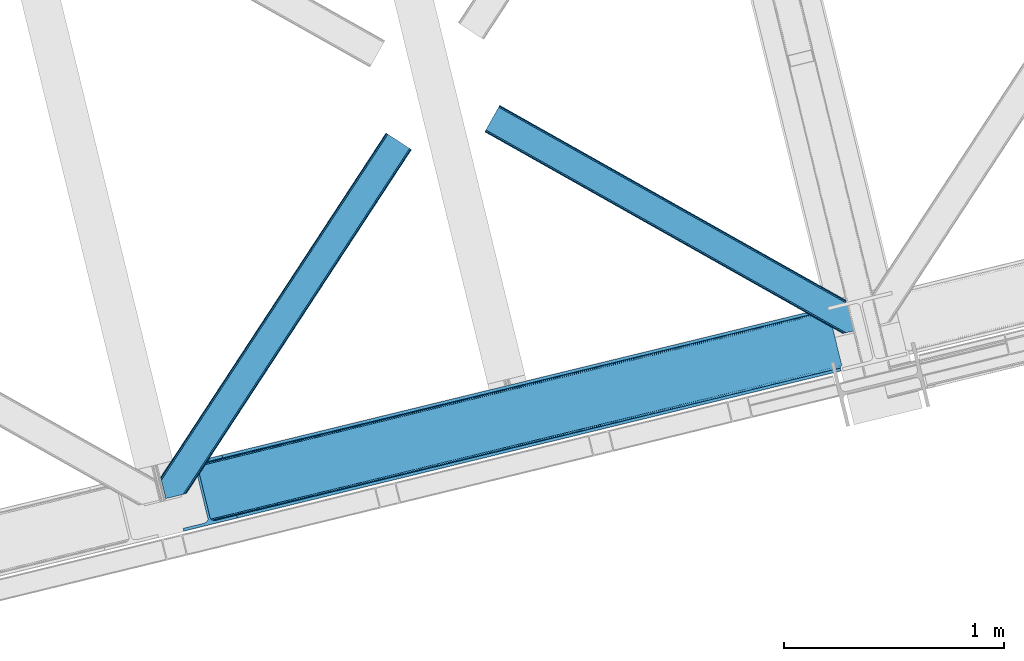
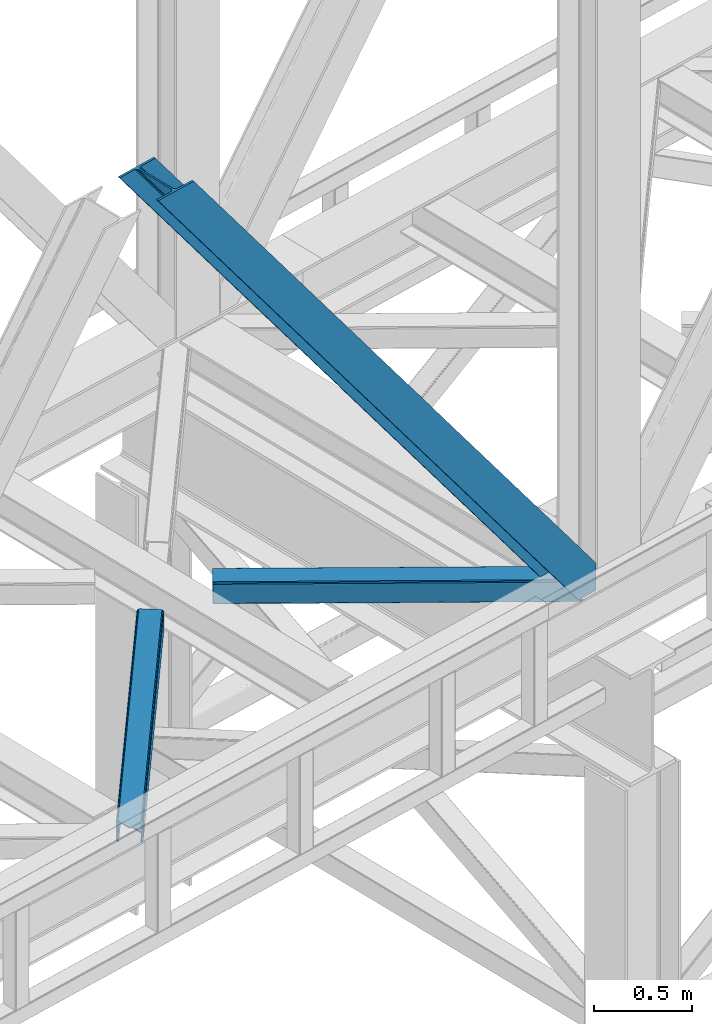
# One storey, part 41 of 93: 3 members.
"""IFC4 building model written with IfcOpenShell, lengths in millimetres."""

from ifc_helpers import new_model, entity, si_unit, converted_unit, derived_unit, direction, frame, origin, place, context, subcontext, project, spatial, triangles, type_object, element, save


model = new_model("IFC4")

# Units and contexts
model_context = context("Model", 3, precision=0.01, world=origin(), true_north=direction((6.12303176911189e-17, 1.0)))
plan_context = context("Plan", 3, precision=0.01, world=origin(), true_north=direction((6.12303176911189e-17, 1.0)))
body_context = subcontext(model_context, "Body", "Model", "MODEL_VIEW")
ifc_project = project(units=[si_unit("LENGTHUNIT", "METRE", prefix="MILLI"), si_unit("AREAUNIT", "SQUARE_METRE"), si_unit("VOLUMEUNIT", "CUBIC_METRE"), converted_unit("PLANEANGLEUNIT", "DEGREE", entity("IfcRatioMeasure", 0.0174532925199433), si_unit("PLANEANGLEUNIT", "RADIAN"), dimensions=[0, 0, 0, 0, 0, 0, 0]), si_unit("MASSUNIT", "GRAM", prefix="KILO"), derived_unit("MASSDENSITYUNIT", [(si_unit("MASSUNIT", "GRAM", prefix="KILO"), 1), (si_unit("LENGTHUNIT", "METRE"), -3)]), derived_unit("MOMENTOFINERTIAUNIT", [(si_unit("LENGTHUNIT", "METRE"), 4)]), si_unit("TIMEUNIT", "SECOND"), si_unit("FREQUENCYUNIT", "HERTZ"), si_unit("THERMODYNAMICTEMPERATUREUNIT", "DEGREE_CELSIUS"), derived_unit("THERMALTRANSMITTANCEUNIT", [(si_unit("MASSUNIT", "GRAM", prefix="KILO"), 1), (si_unit("THERMODYNAMICTEMPERATUREUNIT", "KELVIN"), -1), (si_unit("TIMEUNIT", "SECOND"), -3)]), derived_unit("VOLUMETRICFLOWRATEUNIT", [(si_unit("LENGTHUNIT", "METRE"), 3), (si_unit("TIMEUNIT", "SECOND"), -1)]), derived_unit("MASSFLOWRATEUNIT", [(si_unit("MASSUNIT", "GRAM", prefix="KILO"), 1), (si_unit("TIMEUNIT", "SECOND"), -1)]), derived_unit("ROTATIONALFREQUENCYUNIT", [(si_unit("TIMEUNIT", "SECOND"), -1)]), si_unit("ELECTRICCURRENTUNIT", "AMPERE"), si_unit("ELECTRICVOLTAGEUNIT", "VOLT"), si_unit("POWERUNIT", "WATT"), si_unit("FORCEUNIT", "NEWTON", prefix="KILO"), si_unit("ILLUMINANCEUNIT", "LUX"), si_unit("LUMINOUSFLUXUNIT", "LUMEN"), si_unit("LUMINOUSINTENSITYUNIT", "CANDELA"), derived_unit("USERDEFINED", [(si_unit("MASSUNIT", "GRAM", prefix="KILO"), -1), (si_unit("LENGTHUNIT", "METRE"), -2), (si_unit("TIMEUNIT", "SECOND"), 3), (si_unit("LUMINOUSFLUXUNIT", "LUMEN"), 1)]), derived_unit("LINEARVELOCITYUNIT", [(si_unit("LENGTHUNIT", "METRE"), 1), (si_unit("TIMEUNIT", "SECOND"), -1)]), si_unit("PRESSUREUNIT", "PASCAL"), derived_unit("USERDEFINED", [(si_unit("LENGTHUNIT", "METRE"), -2), (si_unit("MASSUNIT", "GRAM", prefix="KILO"), 1), (si_unit("TIMEUNIT", "SECOND"), -2)]), derived_unit("LINEARFORCEUNIT", [(si_unit("MASSUNIT", "GRAM", prefix="KILO"), 1), (si_unit("LENGTHUNIT", "METRE"), 1), (si_unit("TIMEUNIT", "SECOND"), -2), (si_unit("LENGTHUNIT", "METRE"), -1)]), derived_unit("PLANARFORCEUNIT", [(si_unit("MASSUNIT", "GRAM", prefix="KILO"), 1), (si_unit("LENGTHUNIT", "METRE"), 1), (si_unit("TIMEUNIT", "SECOND"), -2), (si_unit("LENGTHUNIT", "METRE"), -2)])], contexts=[model_context, plan_context])

# Site, building, storey
site_placement = place(None, origin())
site = spatial("IfcSite", under=ifc_project, at=site_placement, CompositionType="ELEMENT")
building_placement = place(site_placement, origin())
building = spatial("IfcBuilding", under=site, at=building_placement, CompositionType="ELEMENT")
storey_placement = place(building_placement, frame((0.0, 0.0, 15900.0)))
storey = spatial("IfcBuildingStorey", under=building, at=storey_placement, CompositionType="ELEMENT", Elevation=15900.0)

# Members
member_type_1 = type_object("IfcMemberType", PredefinedType="BRACE")
member_1_placement = place(storey_placement, frame((-45388.1272338867, 6402.95219421387, 3694.99929199219)))
element("IfcMember", 1, at=member_1_placement, inside=storey, type_object=member_type_1, ObjectType="Steel Vertical Brace", PredefinedType="BRACE", context=body_context, shape_type="Tessellation", body=[
    triangles([(3067.37091064453, 755.49225769043, 0.827856445310317), (3068.02668457032, 754.507434082031, 1.13248901367115), (3066.59886474609, 754.04641571045, 0.0), (3064.67805175782, 761.9255859375, 0.0), (3064.21761474609, 752.731379699707, 7.29955444335792), (3064.21761474609, 752.731379699707, 0.0), (3059.99926757813, 741.228012084961, 0.0), (3059.68765869141, 743.591821289063, 30.563250732419), (3059.80393066406, 742.210510253906, 42.2602111816377), (3059.81788330078, 745.528330993652, 0.0), (3059.81788330078, 745.528330993652, 24.1799194335908), (3059.80393066406, 742.210510253906, 171.115136718749), (3059.99926757813, 741.228012084961, 171.175598144531), (3061.30151367188, 749.56936340332, 14.6921264648408), (3061.30151367188, 749.56936340332, 0.0), (3060.7248046875, 747.995622253418, 18.3872497558586), (215.726367187497, 48.9359664916992, 3911.00081176758), (310.455468749999, 72.0264175415041, 3911.00081176758), (192.834741210936, 54.7931671142578, 3911.00081176758), (198.973901367186, 50.2783264160162, 3911.00081176758), (207.010620117188, 48.2214752197269, 3911.00081176758), (189.532617187499, 61.0782485961918, 3911.00081176758), (3062.84095458985, 729.569421386719, 171.175598144531), (313.534350585935, 59.3963745117189, 3911.00081176758), (3062.84095458985, 729.569421386719, 0.0), (2945.0109375, 700.846755981445, 0.0), (69.865502929686, 0.0, 3911.00081176758), (2941.93205566406, 713.477380371094, 0.0), (66.78662109375, 12.6300430297852, 3911.00081176758), (161.511071777342, 35.72049407959, 3911.00081176758), (3036.65650634766, 736.567831420899, 0.0), (3054.3251953125, 759.401321411133, 0.0), (3054.28798828125, 752.301754760742, 0.0), (179.17976074219, 58.5539840698248, 3911.00081176758), (179.142553710939, 51.4549987792971, 3911.00081176758), (3050.91610107422, 745.469613647461, 0.0), (175.770666503908, 44.622857666016, 3911.00081176758), (3044.72578125, 739.944369506836, 0.0), (169.580346679686, 39.0976135253904, 3911.00081176758), (2999.14251708984, 985.772969055176, 0.0), (123.997082519534, 284.925631713867, 3911.00081176758), (2972.95341796875, 997.915251159669, 0.0), (2981.66916503906, 998.629742431641, 0.0), (106.523730468747, 297.782405090332, 3911.00081176758), (97.8033325195283, 297.06791381836, 3911.00081176758), (2989.70588378907, 996.572891235352, 0.0), (114.560449218749, 295.726135253906, 3911.00081176758), (2995.84504394532, 992.05805053711, 0.0), (120.699609374999, 291.211294555665, 3911.00081176758), (3.07888183593604, 273.977462768555, 3911.00081176758), (2878.22431640625, 974.824800109864, 0.0), (2875.14543457031, 987.454843139649, 0.0), (0.0, 286.608087158203, 3911.00081176758), (3009.50002441406, 988.297233581543, 0.0), (134.354589843751, 287.449896240235, 3911.00081176758), (143.954003906249, 306.906848144531, 3911.00081176758), (243.668847656249, 346.004461669922, 3911.00081176758), (152.023278808592, 310.283386230469, 3911.00081176758), (137.763684082034, 301.381604003906, 3911.00081176758), (134.391796875003, 294.549462890625, 3911.00081176758), (246.747729492185, 333.374418640137, 3911.00081176758), (2992.97545166015, 1016.17750854492, 171.175598144531), (2992.97545166015, 1016.17750854492, 0.0), (2995.81713867188, 1004.51891784668, 171.175598144531), (2996.10084228516, 1003.55792999268, 171.115136718749), (2996.10084228516, 1003.55792999268, 42.2602111816377), (2995.81713867188, 1004.51891784668, 0.0), (3004.85844726562, 996.247911071778, 0.0), (2997.63563232422, 1000.6174118042, 0.0), (3000.81218261718, 997.712356567383, 0.0), (3007.57921142578, 996.176403808594, 0.0), (2996.63104248047, 1002.27719421387, 30.563250732419), (2997.80306396484, 1000.74124145508, 25.1542785644524), (2999.21228027344, 998.890191650391, 18.6337463378877), (3000.81218261718, 997.712356567383, 14.6921264648408), (3004.85844726562, 996.247911071778, 7.29955444335792), (3009.05819091797, 996.424063110352, 1.13248901367115), (3008.92796630859, 995.248553466798, 0.827856445310317)], [[1, 2, 3], [3, 4, 1], [5, 6, 3], [7, 8, 9], [7, 10, 11], [11, 8, 7], [9, 12, 13], [13, 7, 9], [14, 10, 15], [10, 14, 16], [11, 10, 16], [6, 5, 15], [14, 15, 5], [3, 2, 5], [17, 18, 12], [12, 9, 17], [1, 19, 5], [19, 20, 16], [16, 14, 19], [14, 5, 19], [20, 21, 8], [8, 11, 20], [9, 8, 21], [21, 17, 9], [11, 16, 20], [5, 2, 1], [1, 4, 19], [22, 19, 4], [13, 12, 18], [23, 13, 24], [18, 24, 13], [23, 25, 7], [7, 13, 23], [24, 26, 23], [24, 27, 26], [26, 25, 23], [28, 26, 29], [27, 29, 26], [29, 30, 28], [31, 28, 30], [32, 33, 34], [35, 34, 33], [33, 36, 35], [37, 35, 36], [36, 38, 37], [39, 37, 38], [38, 31, 39], [30, 39, 31], [40, 32, 41], [34, 41, 32], [42, 43, 44], [44, 45, 42], [43, 46, 47], [47, 44, 43], [46, 48, 49], [49, 47, 46], [48, 40, 41], [41, 49, 48], [45, 50, 51], [51, 42, 45], [52, 51, 50], [50, 53, 52], [4, 54, 55], [55, 22, 4], [41, 34, 55], [37, 39, 21], [30, 27, 24], [29, 27, 30], [39, 30, 17], [34, 35, 19], [35, 37, 20], [47, 56, 44], [53, 45, 57], [45, 44, 58], [53, 50, 45], [47, 49, 59], [49, 41, 60], [55, 34, 22], [17, 21, 39], [19, 35, 20], [21, 20, 37], [19, 22, 34], [24, 17, 30], [24, 18, 17], [58, 44, 56], [59, 49, 60], [55, 60, 41], [59, 56, 47], [58, 57, 45], [57, 58, 61], [57, 52, 53], [52, 57, 62], [63, 52, 62], [64, 62, 57], [65, 64, 61], [57, 61, 64], [61, 58, 65], [66, 65, 58], [64, 67, 62], [63, 62, 67], [32, 40, 54], [46, 43, 67], [42, 52, 63], [51, 52, 42], [43, 42, 63], [40, 48, 68], [48, 46, 69], [36, 7, 38], [26, 31, 25], [31, 38, 25], [26, 28, 31], [36, 33, 10], [33, 32, 6], [10, 7, 36], [54, 40, 68], [67, 69, 46], [63, 67, 43], [48, 69, 70], [70, 68, 48], [71, 54, 68], [32, 54, 4], [10, 33, 15], [33, 6, 15], [7, 25, 38], [32, 4, 6], [3, 6, 4], [67, 72, 73], [65, 66, 64], [67, 64, 66], [66, 72, 67], [69, 74, 75], [69, 73, 74], [76, 77, 71], [71, 68, 76], [76, 68, 70], [70, 75, 76], [75, 70, 69], [73, 69, 67], [60, 78, 76], [76, 59, 60], [76, 75, 59], [75, 74, 59], [78, 77, 76], [54, 78, 60], [60, 55, 54], [73, 59, 74], [59, 73, 72], [56, 59, 72], [72, 66, 56], [58, 56, 66], [77, 78, 71], [54, 71, 78]]),
])
member_type_2 = type_object("IfcMemberType", PredefinedType="BRACE")
member_2_placement = place(storey_placement, frame((-45423.9436523438, 6551.04489898682, 3511.0000579834)))
element("IfcMember", 2, at=member_2_placement, inside=storey, type_object=member_type_2, ObjectType="Steel Horizontal Brace", PredefinedType="BRACE", context=body_context, shape_type="Tessellation", body=[
    triangles([(109.770043945318, 259.949830627442, 7.52047119140843), (115.030187988283, 238.365682983399, 7.77510681152489), (114.216284179689, 239.946981811524, 8.3320495605476), (108.811962890628, 259.662057495118, 8.52041015625218), (113.634924316408, 239.859196472168, 8.52041015625218), (112.20710449219, 237.677352905273, 8.52041015625218), (91.0363037109419, 232.516621398926, 8.52041015625218), (109.537500000006, 237.026229858398, 9.50058288574292), (90.2642578125015, 232.328260803223, 9.50058288574292), (5.02294921875, 77.405158996582, 9.50058288574292), (0.62786865234375, 95.4308029174808, 9.50058288574292), (1046.62448730469, 1651.75324859619, 6.99957275390625), (1041.02017822266, 1655.4216293335, 8.3320495605476), (116.699853515631, 231.514938354492, 6.99957275390625), (1036.27163085938, 1658.53190460205, 12.1260040283232), (3.92999267578125, 81.8752349853521, 12.1260040283232), (1033.09973144531, 1660.61026611328, 17.8035644531265), (2.70216064453416, 86.9220199584961, 17.8035644531265), (1031.98352050781, 1661.3398727417, 24.4996673583992), (2.26962890625146, 88.6940048217775, 24.4996673583992), (1122.7547241211, 1601.90454711914, 6.99957275390625), (146.209680175787, 110.459536743164, 6.99957275390625), (1031.98352050781, 1661.3398727417, 115.501089477541), (2.26962890625146, 88.6940048217775, 115.501089477541), (1033.09973144531, 1660.61026611328, 122.196029663086), (2.70216064453416, 86.9220199584961, 122.196029663086), (1036.27163085938, 1658.53190460205, 127.87475280762), (3.92999267578125, 81.8752349853521, 127.87475280762), (1041.02017822266, 1655.4216293335, 131.667544555665), (5.77174072265916, 74.322789001465, 131.667544555665), (1046.62448730469, 1651.75324859619, 133.000021362306), (7.94370117187646, 65.4140304565435, 133.000021362306), (1027.24427490235, 1664.44433441162, 10.8028289794929), (0.520898437505821, 95.8714736938482, 10.8691040039084), (0.0, 98.0056457519531, 17.5000946044929), (1035.16472167969, 1659.2562789917, 1.33247680664135), (112.258264160162, 249.73533782959, 1.33247680664135), (110.546740722661, 256.772117614746, 5.59500732422021), (109.077062988283, 259.839372253418, 8.31925964355469), (1030.41617431641, 1662.36655426025, 5.12526855468968), (1040.76903076172, 1655.58789825439, 0.0), (114.430224609379, 240.826579284668, 0.0), (1026.12806396485, 1665.1745223999, 17.5000946044929), (1128.61018066407, 1598.06989746094, 0.0), (148.479309082031, 101.147314453126, 0.0), (150.651269531256, 92.2385559082031, 1.33247680664135), (148.507214355472, 101.029298400879, 8.50064392089917), (152.493017578126, 84.686109924317, 5.12526855468968), (153.348779296881, 81.1822540283201, 8.50064392089917), (1026.12806396485, 1665.1745223999, 122.500662231447), (0.0, 98.0056457519531, 122.500662231447), (1040.76903076172, 1655.58789825439, 139.999594116212), (1035.16472167969, 1659.2562789917, 138.667117309571), (3.50211181640771, 83.6350112915043, 138.667117309571), (5.674072265625, 74.7256713867191, 139.999594116212), (1030.41617431641, 1662.36655426025, 134.874325561526), (1.66036376953707, 91.1874572753904, 134.874325561526), (1027.24427490235, 1664.44433441162, 129.197927856447), (0.432531738282705, 96.2336608886717, 129.197927856447), (23.8915649414121, 0.0, 139.999594116212), (23.8915649414121, 0.0, 133.000021362306), (1128.61018066407, 1598.06989746094, 139.999594116212), (93.3338378906265, 16.9280364990236, 139.999594116212), (1122.7547241211, 1601.90454711914, 133.000021362306), (83.3809570312515, 14.501440429688, 133.000021362306), (1143.25579833984, 1588.48385467529, 122.500662231447), (1142.13958740234, 1589.21346130371, 129.197927856447), (118.225341796875, 22.9951080322271, 122.500662231447), (116.332434082033, 22.5335083007813, 129.197927856447), (1138.96303710938, 1591.29124145508, 134.874325561526), (110.937414550783, 21.2178909301756, 134.874325561526), (1134.2144897461, 1594.40151672363, 138.667117309571), (102.858837890628, 19.2499877929686, 138.667117309571), (1143.25579833984, 1588.48385467529, 17.5000946044929), (118.225341796875, 22.9951080322271, 17.5000946044929), (1142.13958740234, 1589.21346130371, 10.8028289794929), (1133.10758056641, 1595.12647247314, 12.1260040283232), (1136.28413085938, 1593.04811096191, 17.8035644531265), (1137.39569091797, 1592.3185043335, 24.4996673583992), (1138.96303710938, 1591.29124145508, 5.12526855468968), (1134.2144897461, 1594.40151672363, 1.33247680664135), (1128.35903320313, 1598.23616638184, 8.3320495605476), (1133.10758056641, 1595.12647247314, 127.87475280762), (1137.39569091797, 1592.3185043335, 115.501089477541), (1136.28413085938, 1593.04811096191, 122.196029663086), (1128.35903320313, 1598.23616638184, 131.667544555665), (92.9059570312529, 16.8228103637693, 131.667544555665), (100.979882812506, 18.79129486084, 127.87475280762), (106.374902343756, 20.106330871582, 122.196029663086), (108.267810058598, 20.5685119628906, 115.501089477541), (108.267810058598, 20.5685119628906, 24.4996673583992), (100.979882812506, 18.79129486084, 12.1260040283232), (115.472021484376, 22.32421875, 9.50058288574292), (106.374902343756, 20.106330871582, 17.8035644531265), (96.1987792968794, 17.6262496948248, 9.50058288574292), (115.946411132813, 22.4393280029299, 10.8702667236357), (153.060424804688, 80.2392883300781, 9.00061340332104), (152.776721191411, 79.2969039916998, 9.50058288574292), (148.711853027344, 99.8677413940432, 8.8831787109375), (148.604882812506, 99.023606872559, 9.08781738281323), (148.493261718751, 98.1672637939455, 9.29478149414354), (148.381640625004, 97.3225479125977, 9.50058288574292)], [[1, 2, 3], [4, 5, 6], [6, 7, 4], [7, 6, 8], [8, 9, 7], [9, 8, 10], [10, 11, 9], [12, 13, 3], [3, 2, 12], [2, 14, 12], [15, 16, 8], [8, 13, 15], [8, 5, 13], [16, 10, 8], [8, 6, 5], [15, 17, 18], [18, 16, 15], [17, 19, 20], [20, 18, 17], [21, 12, 14], [14, 22, 21], [19, 23, 20], [24, 20, 23], [23, 25, 24], [26, 24, 25], [25, 27, 26], [28, 26, 27], [27, 29, 28], [30, 28, 29], [29, 31, 30], [32, 30, 31], [33, 34, 35], [36, 37, 38], [33, 4, 9], [33, 1, 39], [9, 34, 33], [9, 11, 34], [4, 7, 9], [40, 38, 1], [1, 33, 40], [38, 40, 36], [36, 41, 37], [42, 37, 41], [35, 43, 33], [41, 44, 42], [45, 42, 44], [14, 42, 22], [37, 2, 38], [2, 37, 42], [38, 2, 1], [42, 14, 2], [22, 42, 45], [46, 47, 45], [47, 46, 48], [45, 47, 22], [48, 49, 47], [50, 43, 35], [35, 51, 50], [52, 53, 54], [54, 55, 52], [53, 56, 57], [57, 54, 53], [56, 58, 59], [59, 57, 56], [58, 50, 51], [51, 59, 58], [28, 57, 26], [30, 32, 55], [32, 60, 55], [32, 61, 60], [54, 30, 55], [28, 54, 57], [16, 11, 10], [28, 30, 54], [51, 35, 20], [24, 26, 51], [24, 51, 20], [57, 59, 26], [26, 59, 51], [35, 18, 20], [18, 11, 16], [11, 18, 34], [35, 34, 18], [62, 55, 63], [62, 52, 55], [55, 60, 63], [64, 32, 31], [32, 64, 65], [61, 32, 65], [66, 67, 68], [69, 68, 67], [67, 70, 69], [71, 69, 70], [70, 72, 71], [73, 71, 72], [72, 62, 73], [63, 73, 62], [74, 66, 75], [68, 75, 66], [76, 77, 78], [79, 66, 74], [76, 78, 74], [76, 80, 77], [78, 79, 74], [77, 80, 81], [21, 44, 41], [44, 82, 81], [82, 44, 21], [82, 77, 81], [67, 83, 70], [84, 66, 79], [66, 85, 67], [85, 66, 84], [67, 85, 83], [62, 64, 52], [72, 70, 83], [83, 86, 72], [86, 64, 62], [62, 72, 86], [15, 36, 40], [41, 12, 21], [41, 13, 12], [13, 41, 36], [15, 13, 36], [19, 43, 50], [33, 17, 15], [40, 33, 15], [17, 33, 43], [19, 17, 43], [53, 27, 56], [52, 64, 31], [31, 29, 52], [29, 27, 53], [53, 52, 29], [58, 56, 27], [50, 23, 19], [25, 50, 58], [50, 25, 23], [25, 58, 27], [64, 86, 87], [87, 65, 64], [86, 83, 88], [88, 87, 86], [83, 85, 89], [89, 88, 83], [85, 84, 90], [90, 89, 85], [84, 79, 90], [91, 90, 79], [89, 68, 69], [87, 73, 63], [60, 65, 63], [65, 60, 61], [65, 87, 63], [88, 73, 87], [88, 89, 71], [71, 73, 88], [69, 71, 89], [91, 75, 68], [92, 93, 94], [89, 90, 68], [92, 95, 93], [91, 94, 75], [90, 91, 68], [96, 75, 94], [94, 93, 96], [76, 74, 75], [49, 80, 97], [98, 97, 80], [49, 48, 80], [76, 96, 98], [98, 80, 76], [96, 93, 98], [44, 81, 45], [46, 45, 81], [81, 80, 46], [48, 46, 80], [75, 96, 76], [82, 21, 22], [77, 82, 47], [47, 99, 77], [77, 100, 101], [100, 77, 99], [101, 102, 77], [77, 102, 92], [95, 92, 102], [22, 47, 82], [79, 78, 91], [94, 91, 78], [78, 77, 94], [92, 94, 77], [102, 101, 98], [101, 100, 97], [100, 99, 49], [99, 47, 49], [102, 98, 93], [93, 95, 102]]),
])
member_type_3 = type_object("IfcMemberType", PredefinedType="BRACE")
member_3_placement = place(storey_placement, frame((-43947.8663085938, 7302.47054443359, 3511.0000579834)))
element("IfcMember", 3, at=member_3_placement, inside=storey, type_object=member_type_3, ObjectType="Steel Horizontal Brace", PredefinedType="BRACE", context=body_context, shape_type="Tessellation", body=[
    triangles([(1645.8158203125, 3.74512023925763, 138.667117309571), (1655.3408203125, 6.06707153320258, 139.999594116212), (8.59017333984229, 933.436047363281, 139.999594116212), (5.302001953125, 927.600938415528, 138.667117309571), (1637.74189453125, 1.7772171020506, 134.874325561526), (2.51612548828416, 922.653565979004, 134.874325561526), (1632.346875, 0.461599731444949, 129.197927856447), (0.65577392578416, 919.34853515625, 129.197927856447), (1630.44931640625, 0.0, 122.500662231447), (0.0, 918.187559509277, 122.500662231447), (1630.44931640625, 0.0, 17.5000946044929), (0.0, 918.187559509277, 17.5000946044929), (1706.57490234375, 97.721360778809, 139.999594116212), (1724.78774414062, 22.9956893920898, 139.999594116212), (60.1126098632813, 1024.92639312744, 139.999594116212), (1701.3287109375, 119.229350280762, 129.197927856447), (1700.89617919922, 121.001335144043, 122.500662231447), (68.0423583984375, 1039.01390533447, 129.197927856447), (68.6981323242217, 1040.17488098145, 122.500662231447), (1702.56119384766, 114.18314666748, 134.874325561526), (66.1820068359375, 1035.70829315186, 134.874325561526), (1704.40294189453, 106.630700683594, 138.667117309571), (63.3961303710967, 1030.76150207519, 138.667117309571), (1700.89617919922, 121.001335144043, 17.5000946044929), (68.6981323242217, 1040.17488098145, 17.5000946044929), (0.65577392578416, 919.34853515625, 10.8028289794929), (1633.02590332031, 0.628450012206486, 10.9377044677749), (2.51612548828416, 922.653565979004, 5.12526855468968), (5.302001953125, 927.600938415528, 1.33247680664135), (1569.79720458984, 46.5547164916989, 1.33247680664135), (1573.68999023437, 34.8100845336912, 8.52041015625218), (1571.51337890625, 39.517936706543, 5.59500732422021), (1572.2900756836, 36.3402236938473, 7.52047119140843), (1572.98770751953, 35.5751541137697, 8.02044067383031), (1573.35047607422, 35.1809921264648, 8.278564453125), (1572.62958984375, 35.9693161010746, 7.76231689453198), (1633.97933349609, 0.859831237792605, 8.52041015625218), (1567.62524414063, 55.4634750366213, 0.0), (8.59017333984229, 933.436047363281, 0.0), (1533.58081054688, 195.142739868164, 0.0), (60.1126098632813, 1024.92639312744, 0.0), (1566.73227539063, 59.1411575317379, 7.52047119140843), (1567.24852294922, 57.3430114746097, 7.90300598144677), (1567.78337402343, 56.436090087891, 8.1076446533225), (1568.32752685547, 55.5198669433594, 8.31460876464917), (1568.41124267578, 55.3762710571291, 8.3471649169951), (1568.86237792969, 54.6129455566406, 8.52041015625218), (1655.15013427734, 6.02056274414008, 8.52041015625218), (5.953125, 928.75319366455, 12.1260040283232), (1647.69942626953, 4.20381317138617, 12.1260040283232), (8.73900146484084, 933.699984741212, 8.3320495605476), (12.0225219726563, 939.535093688964, 6.99957275390625), (1565.35561523437, 64.7751159667969, 6.99957275390625), (1642.29975585938, 2.88877716064417, 17.8035644531265), (4.08812255859084, 925.447581481934, 17.8035644531265), (1640.40684814453, 2.42659606933557, 24.4996673583992), (3.43699951171584, 924.287187194825, 24.4996673583992), (1640.40684814453, 2.42659606933557, 115.501089477541), (3.43699951171584, 924.287187194825, 115.501089477541), (1647.69942626953, 4.20381317138617, 127.87475280762), (1655.77335205078, 6.17229766845685, 131.667544555665), (1642.29975585938, 2.88877716064417, 122.196029663086), (1665.29835205078, 8.4942489624018, 133.000021362306), (1724.78774414062, 22.9956893920898, 133.000021362306), (4.08812255859084, 925.447581481934, 122.196029663086), (5.953125, 928.75319366455, 127.87475280762), (8.73900146484084, 933.699984741212, 131.667544555665), (12.0225219726563, 939.535093688964, 133.000021362306), (1708.84453125, 88.4097198486324, 133.000021362306), (56.6756103515654, 1018.82676544189, 133.000021362306), (1535.85043945313, 185.830517578125, 6.99957275390625), (56.6756103515654, 1018.82676544189, 6.99957275390625), (68.0423583984375, 1039.01390533447, 10.8028289794929), (62.7496582031235, 1029.60924682617, 12.1260040283232), (64.6100097656235, 1032.91485900879, 17.8035644531265), (65.2611328124985, 1034.0752532959, 24.4996673583992), (66.1820068359375, 1035.70829315186, 5.12526855468968), (63.3961303710967, 1030.76150207519, 1.33247680664135), (59.9637817382827, 1024.66245574951, 8.3320495605476), (62.7496582031235, 1029.60924682617, 127.87475280762), (65.2611328124985, 1034.0752532959, 115.501089477541), (64.6100097656235, 1032.91485900879, 122.196029663086), (59.9637817382827, 1024.66245574951, 131.667544555665), (1703.16580810547, 111.689694213867, 24.4996673583992), (1703.16580810547, 111.689694213867, 115.501089477541), (1706.67257080078, 97.3184783935549, 131.667544555665), (1704.83082275391, 104.870924377441, 127.87475280762), (1703.59833984375, 109.917709350586, 122.196029663086), (1704.83082275391, 104.870924377441, 12.1260040283232), (1706.52839355469, 97.9004196166989, 8.52041015625218), (1701.70078125, 117.703280639648, 8.52041015625218), (1703.59833984375, 109.917709350586, 17.8035644531265), (1701.48684082031, 118.591017150879, 10.9365417480476), (1534.47377929687, 191.464476013183, 7.52047119140843), (1529.69267578125, 211.087696838379, 5.59500732422021), (1528.9159790039, 214.265991210938, 7.52047119140843), (1531.40885009766, 204.051498413086, 1.33247680664135), (1529.11596679688, 214.689221191406, 8.22740478515698), (1529.01829833984, 214.477606201172, 7.87393798828271), (1529.90196533203, 214.452026367188, 8.52041015625218), (1534.34820556641, 192.705679321289, 7.85649719238427), (1534.72957763672, 194.649165344238, 8.52041015625218)], [[1, 2, 3], [3, 4, 1], [5, 1, 4], [4, 6, 5], [7, 5, 6], [6, 8, 7], [9, 7, 8], [8, 10, 9], [11, 9, 10], [10, 12, 11], [2, 13, 3], [2, 14, 13], [15, 3, 13], [16, 17, 18], [19, 18, 17], [20, 16, 21], [18, 21, 16], [22, 20, 23], [21, 23, 20], [13, 22, 15], [23, 15, 22], [17, 24, 19], [25, 19, 24], [26, 27, 11], [28, 29, 30], [27, 26, 31], [26, 28, 32], [32, 33, 26], [34, 35, 26], [35, 31, 26], [26, 36, 34], [26, 33, 36], [31, 37, 27], [30, 32, 28], [38, 30, 29], [29, 39, 38], [11, 12, 26], [40, 38, 39], [39, 41, 40], [33, 42, 43], [36, 43, 44], [34, 44, 45], [35, 46, 47], [35, 45, 46], [47, 31, 35], [45, 35, 34], [44, 34, 36], [43, 36, 33], [48, 37, 47], [31, 47, 37], [49, 50, 47], [47, 51, 49], [47, 46, 51], [50, 48, 47], [52, 43, 42], [51, 46, 45], [45, 52, 51], [45, 44, 52], [43, 52, 44], [42, 53, 52], [54, 50, 49], [49, 55, 54], [56, 54, 55], [55, 57, 56], [58, 56, 57], [57, 59, 58], [60, 61, 1], [5, 60, 1], [5, 7, 62], [60, 5, 62], [62, 7, 9], [61, 2, 1], [14, 63, 64], [14, 2, 63], [61, 63, 2], [62, 9, 58], [56, 11, 54], [9, 56, 58], [11, 27, 54], [9, 11, 56], [37, 54, 27], [50, 54, 37], [48, 50, 37], [62, 58, 65], [59, 65, 58], [60, 62, 66], [65, 66, 62], [61, 60, 67], [66, 67, 60], [63, 61, 68], [67, 68, 61], [69, 63, 68], [63, 69, 64], [68, 70, 69], [53, 71, 52], [72, 52, 71], [73, 74, 75], [76, 19, 25], [73, 75, 25], [73, 77, 74], [75, 76, 25], [74, 77, 78], [72, 41, 39], [41, 79, 78], [79, 41, 72], [79, 74, 78], [18, 80, 21], [81, 19, 76], [19, 82, 18], [82, 19, 81], [18, 82, 80], [15, 70, 3], [23, 21, 80], [80, 83, 23], [83, 70, 15], [15, 23, 83], [49, 29, 28], [39, 52, 72], [39, 51, 52], [51, 39, 29], [49, 51, 29], [57, 12, 10], [26, 55, 49], [28, 26, 49], [55, 26, 12], [57, 55, 12], [4, 66, 6], [3, 70, 68], [68, 67, 3], [67, 66, 4], [4, 3, 67], [8, 6, 66], [10, 59, 57], [65, 10, 8], [10, 65, 59], [65, 8, 66], [84, 85, 76], [81, 76, 85], [86, 69, 70], [70, 83, 86], [87, 86, 83], [83, 80, 87], [88, 87, 80], [80, 82, 88], [85, 88, 82], [82, 81, 85], [87, 20, 22], [89, 90, 91], [20, 87, 88], [86, 87, 22], [86, 13, 69], [14, 69, 13], [69, 14, 64], [86, 22, 13], [24, 17, 84], [91, 92, 89], [92, 24, 84], [93, 92, 91], [93, 24, 92], [17, 85, 84], [88, 16, 20], [17, 16, 88], [85, 17, 88], [40, 71, 53], [94, 95, 96], [40, 94, 71], [94, 97, 95], [94, 40, 97], [38, 40, 53], [42, 38, 53], [32, 42, 33], [42, 30, 38], [42, 32, 30], [73, 25, 24], [98, 99, 77], [96, 77, 99], [96, 95, 77], [73, 93, 100], [100, 77, 73], [100, 98, 77], [93, 91, 100], [78, 77, 95], [97, 40, 41], [41, 78, 97], [95, 97, 78], [24, 93, 73], [72, 71, 94], [94, 79, 72], [101, 102, 79], [79, 94, 101], [74, 79, 102], [90, 89, 102], [74, 102, 89], [92, 84, 75], [76, 75, 84], [89, 92, 74], [75, 74, 92], [101, 94, 99], [102, 101, 99], [91, 90, 102], [102, 100, 91]]),
])

save(model, "model.ifc")
